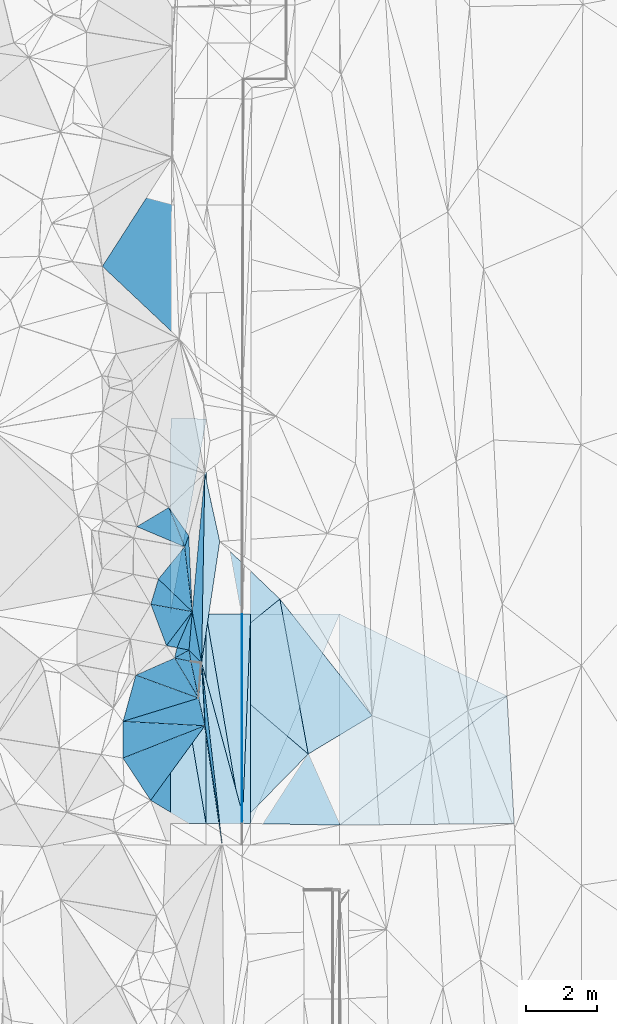
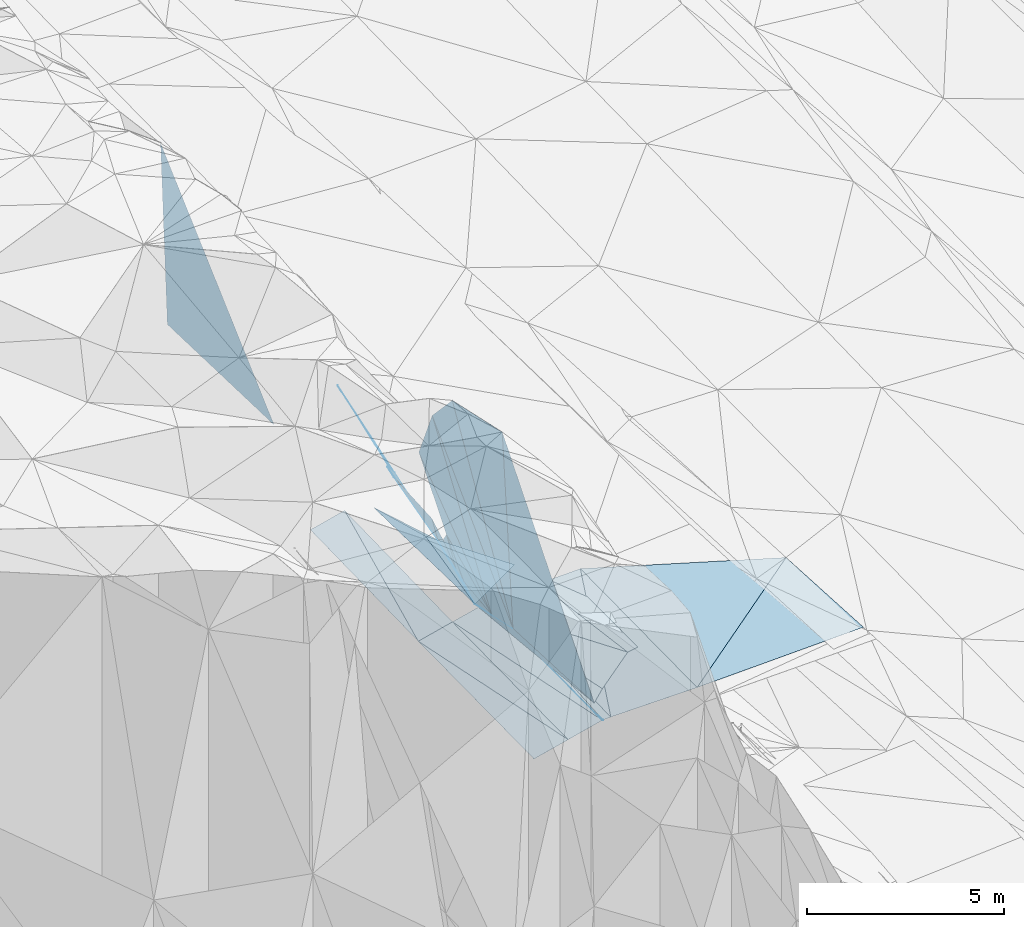
# One storey, part 88 of 275: 45 plates.
"""IFC2X3 building model written with IfcOpenShell, lengths in millimetres."""

from ifc_helpers import new_model, si_unit, frame, origin_with_axes, place, context, subcontext, project, spatial, polyline, outline, extrude, material, type_object, element, save


model = new_model("IFC2X3")

# Units and contexts
model_context = context("Model", 3, precision=1e-05, world=origin_with_axes())
body_context = subcontext(model_context, "Body", "Model", "MODEL_VIEW")
ifc_project = project(units=[si_unit("LENGTHUNIT", "METRE", prefix="MILLI"), si_unit("AREAUNIT", "SQUARE_METRE"), si_unit("VOLUMEUNIT", "CUBIC_METRE"), si_unit("MASSUNIT", "GRAM", prefix="KILO"), si_unit("TIMEUNIT", "SECOND"), si_unit("PLANEANGLEUNIT", "RADIAN"), si_unit("SOLIDANGLEUNIT", "STERADIAN"), si_unit("THERMODYNAMICTEMPERATUREUNIT", "DEGREE_CELSIUS"), si_unit("LUMINOUSINTENSITYUNIT", "LUMEN")], contexts=[model_context])

# Site, building, storey
site_placement = place(None, origin_with_axes())
site = spatial("IfcSite", under=ifc_project, at=site_placement, CompositionType="ELEMENT")
building_placement = place(site_placement, origin_with_axes())
building = spatial("IfcBuilding", under=site, at=building_placement, Name="Undefined", CompositionType="ELEMENT")
storey_placement = place(building_placement, origin_with_axes())
storey = spatial("IfcBuildingStorey", under=building, at=storey_placement, Name="Undefined", CompositionType="ELEMENT", Elevation=0.0)

# Plates
ifc_material = material()
plate_type_1 = type_object("IfcPlateType", PredefinedType="NOTDEFINED")
plate_1_placement = place(storey_placement, frame((-96893.2060687271, 88513.7220554955, 42669.7156715299), z_axis=(0.0499446714186171, 0.0138763250897075, -0.998655584973564), x_axis=(0.998751959117345, -0.000926466934522729, 0.0499366180100698)))
element("IfcPlate", 1, at=plate_1_placement, inside=storey, type_object=plate_type_1, material=ifc_material, Name="00_PR", context=body_context, shape_type="SweptSolid", body=[
    extrude(outline(polyline([(0.0, 0.0), (20.0253849029541, -2.91038304567337e-11), (18.7645778656006, 5873.8154296875), (0.0, 0.0)])), frame((-8.85201319254618e-08, 2.18876761149539e-07, -0.5000001331573), z_axis=(0.0, 0.0, 1.0), x_axis=(1.0, 0.0, 0.0)), (0.0, 0.0, 1.0), 1.0),
])
plate_2_placement = place(storey_placement, frame((-96875.8293149701, 82640.4574952673, 42588.975671324), z_axis=(0.0499313186515938, 0.0138762943318531, -0.998656253108811), x_axis=(-0.998752336887463, -0.000102790084437559, -0.0499375509614761)))
element("IfcPlate", 2, at=plate_2_placement, inside=storey, type_object=plate_type_1, material=ifc_material, Name="00_PR", context=body_context, shape_type="SweptSolid", body=[
    extrude(outline(polyline([(0.0, 0.0), (20.0249881744385, 1.60071067512035e-10), (12.719409942627, 5873.83154296875), (0.0, 0.0)])), frame((-8.85201319254618e-08, 2.18876761149539e-07, -0.5000001331573), z_axis=(0.0, 0.0, 1.0), x_axis=(1.0, 0.0, 0.0)), (0.0, 0.0, 1.0), 1.0),
])
plate_type_2 = type_object("IfcPlateType", PredefinedType="NOTDEFINED")
plate_3_placement = place(storey_placement, frame((-96643.206190822, 88513.4879067641, 42682.2156707472), z_axis=(0.0499458955257397, 0.0138763235076021, -0.998655523774862), x_axis=(-0.0395726899371841, -0.999090793774861, -0.0158615259496958)))
element("IfcPlate", 3, at=plate_3_placement, inside=storey, type_object=plate_type_2, material=ifc_material, Name="00_PR", context=body_context, shape_type="SweptSolid", body=[
    extrude(outline(polyline([(0.0, 0.0), (5878.375, 8.45466274768114e-09), (9.06870937347412, 230.108276367188), (0.0, 0.0)])), frame((-8.85201319254618e-08, 2.18876761149539e-07, -0.5000001331573), z_axis=(0.0, 0.0, 1.0), x_axis=(1.0, 0.0, 0.0)), (0.0, 0.0, 1.0), 1.0),
])
plate_4_placement = place(storey_placement, frame((-96875.8293149701, 82640.4574952673, 42588.975671324), z_axis=(0.049932272950596, 0.0138768737776843, -0.998656197343283), x_axis=(0.0395726899278076, 0.999090793775177, 0.0158615259532447)))
element("IfcPlate", 4, at=plate_4_placement, inside=storey, type_object=plate_type_2, material=ifc_material, Name="00_PR", context=body_context, shape_type="SweptSolid", body=[
    extrude(outline(polyline([(0.0, 0.0), (5878.375, 8.45466274768114e-09), (9.07760524749756, 230.108184814453), (0.0, 0.0)])), frame((-8.85201319254618e-08, 2.18876761149539e-07, -0.5000001331573), z_axis=(0.0, 0.0, 1.0), x_axis=(1.0, 0.0, 0.0)), (0.0, 0.0, 1.0), 1.0),
])
plate_type_3 = type_object("IfcPlateType", PredefinedType="NOTDEFINED")
plate_5_placement = place(storey_placement, frame((-98777.8240217178, 87283.3001653632, 46179.8436901109), z_axis=(-0.934762478303798, -0.168849738440227, -0.312584188634053), x_axis=(0.144226771959562, 0.623726465579778, -0.768221279570856)))
element("IfcPlate", 5, at=plate_5_placement, inside=storey, type_object=plate_type_3, material=ifc_material, Name="00", context=body_context, shape_type="SweptSolid", body=[
    extrude(outline(polyline([(0.0, 0.0), (468.614990234375, -1.94995664060116e-09), (1218.9111328125, 704.525207519531), (0.0, 0.0)])), frame((-8.85201319254618e-08, 2.18876761149539e-07, -0.5000001331573), z_axis=(0.0, 0.0, 1.0), x_axis=(1.0, 0.0, 0.0)), (0.0, 0.0, 1.0), 1.0),
])
plate_type_4 = type_object("IfcPlateType", PredefinedType="NOTDEFINED")
plate_6_placement = place(storey_placement, frame((-96895.7330487031, 82640.4551932555, 42587.9899716157), z_axis=(0.242514042864615, 0.0133900825096925, -0.970055485373823), x_axis=(-0.970142022389103, -0.000132066070191462, -0.242537500097065)))
element("IfcPlate", 6, at=plate_6_placement, inside=storey, type_object=plate_type_4, material=ifc_material, Name="00_PR", context=body_context, shape_type="SweptSolid", body=[
    extrude(outline(polyline([(0.0, 0.0), (1030.77673339844, -2.18278728425503e-09), (1007.62969970703, 5874.8642578125), (0.0, 0.0)])), frame((-8.85201319254618e-08, 2.18876761149539e-07, -0.5000001331573), z_axis=(0.0, 0.0, 1.0), x_axis=(1.0, 0.0, 0.0)), (0.0, 0.0, 1.0), 1.0),
])
plate_7_placement = place(storey_placement, frame((-98893.1086731115, 88515.5972124525, 42169.7299724131), z_axis=(0.242525718614179, 0.0133900365415608, -0.970052566994228), x_axis=(0.97014209331027, -0.000909506926827291, 0.242535547053866)))
element("IfcPlate", 7, at=plate_7_placement, inside=storey, type_object=plate_type_4, material=ifc_material, Name="00_PR", context=body_context, shape_type="SweptSolid", body=[
    extrude(outline(polyline([(0.0, 0.0), (1030.77673339844, -2.18278728425503e-09), (1013.74847412109, 5874.88525390625), (0.0, 0.0)])), frame((-8.85201319254618e-08, 2.18876761149539e-07, -0.5000001331573), z_axis=(0.0, 0.0, 1.0), x_axis=(1.0, 0.0, 0.0)), (0.0, 0.0, 1.0), 1.0),
])
plate_8_placement = place(storey_placement, frame((-97895.7328316384, 82640.3190606472, 42337.9879714203), z_axis=(0.242513080573576, 0.0133878003581773, -0.970055757445047), x_axis=(-0.970142285513392, -0.000125957083561735, -0.24253645085567)))
element("IfcPlate", 8, at=plate_8_placement, inside=storey, type_object=plate_type_4, material=ifc_material, Name="00_PR", context=body_context, shape_type="SweptSolid", body=[
    extrude(outline(polyline([(0.0, 0.0), (1030.77697753906, -6.40284270048141e-10), (1007.66516113281, 5875.931640625), (0.0, 0.0)])), frame((-8.85201319254618e-08, 2.18876761149539e-07, -0.5000001331573), z_axis=(0.0, 0.0, 1.0), x_axis=(1.0, 0.0, 0.0)), (0.0, 0.0, 1.0), 1.0),
])
plate_9_placement = place(storey_placement, frame((-96895.7330487031, 82640.4551932555, 42587.9899716157), z_axis=(0.242525927545309, 0.0133921862289311, -0.970052485083306), x_axis=(-0.167326671140559, 0.985497305366927, -0.028228465058257)))
element("IfcPlate", 9, at=plate_9_placement, inside=storey, type_object=plate_type_4, material=ifc_material, Name="00_PR", context=body_context, shape_type="SweptSolid", body=[
    extrude(outline(polyline([(0.0, 0.0), (5960.64990234375, -9.22591425478458e-09), (5785.34228515625, 1015.75885009766), (0.0, 0.0)])), frame((-8.85201319254618e-08, 2.18876761149539e-07, -0.5000001331573), z_axis=(0.0, 0.0, 1.0), x_axis=(1.0, 0.0, 0.0)), (0.0, 0.0, 1.0), 1.0),
])
plate_type_5 = type_object("IfcPlateType", PredefinedType="NOTDEFINED")
plate_10_placement = place(storey_placement, frame((-97885.4748993714, 93996.4223844133, 42542.8030438031), z_axis=(0.242517661901467, 0.0214344360912746, -0.969910175539619), x_axis=(-0.180412993918953, -0.981320168044632, -0.0667973009488785)))
element("IfcPlate", 10, at=plate_10_placement, inside=storey, type_object=plate_type_5, material=ifc_material, Name="00_PR", context=body_context, shape_type="SweptSolid", body=[
    extrude(outline(polyline([(0.0, 0.0), (5585.15087890625, -2.30938894674182e-08), (195.298400878906, 1012.10559082031), (0.0, 0.0)])), frame((-8.85201319254618e-08, 2.18876761149539e-07, -0.5000001331573), z_axis=(0.0, 0.0, 1.0), x_axis=(1.0, 0.0, 0.0)), (0.0, 0.0, 1.0), 1.0),
])
plate_11_placement = place(storey_placement, frame((-98893.1086889943, 88515.6012354554, 42169.7300417344), z_axis=(0.242499038802853, 0.0214382132062527, -0.969914748415661), x_axis=(0.180412993916078, 0.981320168044951, 0.0667973009519616)))
element("IfcPlate", 11, at=plate_11_placement, inside=storey, type_object=plate_type_5, material=ifc_material, Name="00_PR", context=body_context, shape_type="SweptSolid", body=[
    extrude(outline(polyline([(0.0, 0.0), (5585.15087890625, -2.30938894674182e-08), (196.192321777344, 1011.93341064453), (0.0, 0.0)])), frame((-8.85201319254618e-08, 2.18876761149539e-07, -0.5000001331573), z_axis=(0.0, 0.0, 1.0), x_axis=(1.0, 0.0, 0.0)), (0.0, 0.0, 1.0), 1.0),
])
plate_type_6 = type_object("IfcPlateType", PredefinedType="NOTDEFINED")
plate_12_placement = place(storey_placement, frame((-98321.0967344729, 87190.1452454578, 44619.8206200758), z_axis=(-0.927169515903314, 0.108044872178601, -0.358724120147396), x_axis=(-0.132361426280136, 0.801291839814366, 0.583448232733631)))
element("IfcPlate", 12, at=plate_12_placement, inside=storey, type_object=plate_type_6, material=ifc_material, Name="00", context=body_context, shape_type="SweptSolid", body=[
    extrude(outline(polyline([(0.0, 0.0), (394.208068847656, 5.0931703299284e-10), (-525.559997558594, 656.521667480469), (0.0, 0.0)])), frame((-8.85201319254618e-08, 2.18876761149539e-07, -0.5000001331573), z_axis=(0.0, 0.0, 1.0), x_axis=(1.0, 0.0, 0.0)), (0.0, 0.0, 1.0), 1.0),
])
plate_type_7 = type_object("IfcPlateType", PredefinedType="NOTDEFINED")
plate_13_placement = place(storey_placement, frame((-89450.8198160826, 86219.6799809092, 42848.685236372), z_axis=(0.0255600534766199, 0.0172621321198634, -0.999524238055761), x_axis=(0.0555775201133517, -0.998329033409946, -0.0158202499605024)))
element("IfcPlate", 13, at=plate_13_placement, inside=storey, type_object=plate_type_7, material=ifc_material, Name="00_PR", context=body_context, shape_type="SweptSolid", body=[
    extrude(outline(polyline([(0.0, 0.0), (3585.7841796875, -4.32191882282496e-09), (3360.41650390625, 4891.17724609375), (0.0, 0.0)])), frame((-8.85201319254618e-08, 2.18876761149539e-07, -0.5000001331573), z_axis=(0.0, 0.0, 1.0), x_axis=(1.0, 0.0, 0.0)), (0.0, 0.0, 1.0), 1.0),
])
plate_type_8 = type_object("IfcPlateType", PredefinedType="NOTDEFINED")
plate_14_placement = place(storey_placement, frame((-98281.8003223209, 88585.1772316541, 45059.8151830201), z_axis=(-0.917061441723247, 0.149655219156459, -0.369596573961003), x_axis=(0.136984403376972, -0.752244078327522, -0.64448748618777)))
element("IfcPlate", 14, at=plate_14_placement, inside=storey, type_object=plate_type_8, material=ifc_material, Name="00", context=body_context, shape_type="SweptSolid", body=[
    extrude(outline(polyline([(0.0, 0.0), (1900.73510742188, 9.85164660960436e-09), (934.585754394531, 586.130920410156), (0.0, 0.0)])), frame((-8.85201319254618e-08, 2.18876761149539e-07, -0.5000001331573), z_axis=(0.0, 0.0, 1.0), x_axis=(1.0, 0.0, 0.0)), (0.0, 0.0, 1.0), 1.0),
])
plate_type_9 = type_object("IfcPlateType", PredefinedType="NOTDEFINED")
plate_15_placement = place(storey_placement, frame((-94147.9689940766, 88514.5259286479, 42755.1682607573), z_axis=(0.0292156920013798, 0.0138975437163812, -0.99947651379086), x_axis=(-0.391198783795324, -0.91998725272795, -0.0242273889459753)))
element("IfcPlate", 15, at=plate_15_placement, inside=storey, type_object=plate_type_9, material=ifc_material, Name="00_PR", context=body_context, shape_type="SweptSolid", body=[
    extrude(outline(polyline([(0.0, 0.0), (6385.169921875, -1.02008925750852e-08), (978.860229492188, 2296.39208984375), (0.0, 0.0)])), frame((-8.85201319254618e-08, 2.18876761149539e-07, -0.5000001331573), z_axis=(0.0, 0.0, 1.0), x_axis=(1.0, 0.0, 0.0)), (0.0, 0.0, 1.0), 1.0),
])
plate_type_10 = type_object("IfcPlateType", PredefinedType="NOTDEFINED")
plate_16_placement = place(storey_placement, frame((-96645.841133087, 82640.2514278124, 42600.4722312239), z_axis=(0.0264812327337204, 0.0150618580365435, -0.999535834647958), x_axis=(0.391198783793806, 0.919987252728506, 0.0242273889493393)))
element("IfcPlate", 16, at=plate_16_placement, inside=storey, type_object=plate_type_10, material=ifc_material, Name="00_PR", context=body_context, shape_type="SweptSolid", body=[
    extrude(outline(polyline([(0.0, 0.0), (6385.169921875, -1.02008925750852e-08), (937.997375488281, 2318.47705078125), (0.0, 0.0)])), frame((-8.85201319254618e-08, 2.18876761149539e-07, -0.5000001331573), z_axis=(0.0, 0.0, 1.0), x_axis=(1.0, 0.0, 0.0)), (0.0, 0.0, 1.0), 1.0),
])
plate_type_11 = type_object("IfcPlateType", PredefinedType="NOTDEFINED")
plate_17_placement = place(storey_placement, frame((-94146.0719650738, 82595.1451738821, 42666.0202418753), z_axis=(0.0272582592440568, 0.0150617925048628, -0.999514947216661), x_axis=(-0.00032060709218387, 0.999886560717147, 0.0150586489542769)))
element("IfcPlate", 17, at=plate_17_placement, inside=storey, type_object=plate_type_11, material=ifc_material, Name="00_PR", context=body_context, shape_type="SweptSolid", body=[
    extrude(outline(polyline([(0.0, 0.0), (5920.052734375, 5.80621417611837e-09), (3625.36791992188, 4698.1611328125), (0.0, 0.0)])), frame((-8.85201319254618e-08, 2.18876761149539e-07, -0.5000001331573), z_axis=(0.0, 0.0, 1.0), x_axis=(1.0, 0.0, 0.0)), (0.0, 0.0, 1.0), 1.0),
])
plate_type_12 = type_object("IfcPlateType", PredefinedType="NOTDEFINED")
plate_18_placement = place(storey_placement, frame((-99232.3742871963, 89498.8382816605, 47089.7596187691), z_axis=(-0.859458469478843, 0.173882204639042, -0.480724576187811), x_axis=(0.481452232243517, 0.591457912349138, -0.646823999235753)))
element("IfcPlate", 18, at=plate_18_placement, inside=storey, type_object=plate_type_12, material=ifc_material, Name="00", context=body_context, shape_type="SweptSolid", body=[
    extrude(outline(polyline([(0.0, 0.0), (1530.55541992188, -8.14907252788544e-09), (1230.33764648438, 2084.60278320313), (0.0, 0.0)])), frame((-8.85201319254618e-08, 2.18876761149539e-07, -0.5000001331573), z_axis=(0.0, 0.0, 1.0), x_axis=(1.0, 0.0, 0.0)), (0.0, 0.0, 1.0), 1.0),
])
plate_type_13 = type_object("IfcPlateType", PredefinedType="NOTDEFINED")
plate_19_placement = place(storey_placement, frame((-98105.7364801051, 86159.0151946346, 44149.6651417027), z_axis=(-0.727312380144922, -0.150134864681754, -0.669683674651637), x_axis=(0.0805198648191997, 0.950373459793389, -0.30051096201277)))
element("IfcPlate", 19, at=plate_19_placement, inside=storey, type_object=plate_type_13, material=ifc_material, Name="00", context=body_context, shape_type="SweptSolid", body=[
    extrude(outline(polyline([(0.0, 0.0), (1048.21472167969, 3.11410985887051e-09), (-715.273315429688, 345.953857421875), (0.0, 0.0)])), frame((-8.85201319254618e-08, 2.18876761149539e-07, -0.5000001331573), z_axis=(0.0, 0.0, 1.0), x_axis=(1.0, 0.0, 0.0)), (0.0, 0.0, 1.0), 1.0),
])
plate_type_14 = type_object("IfcPlateType", PredefinedType="NOTDEFINED")
plate_20_placement = place(storey_placement, frame((-98105.8628060344, 86159.1004533628, 44149.9009383734), z_axis=(-0.979972063051786, 0.0203914954245451, -0.198088219115566), x_axis=(0.068057929838988, 0.969140463819479, -0.236928005043297)))
element("IfcPlate", 20, at=plate_20_placement, inside=storey, type_object=plate_type_14, material=ifc_material, Name="00", context=body_context, shape_type="SweptSolid", body=[
    extrude(outline(polyline([(0.0, 0.0), (1012.96594238281, -7.56699591875076e-10), (1045.82983398438, 70.6679916381836), (0.0, 0.0)])), frame((-8.85201319254618e-08, 2.18876761149539e-07, -0.5000001331573), z_axis=(0.0, 0.0, 1.0), x_axis=(1.0, 0.0, 0.0)), (0.0, 0.0, 1.0), 1.0),
])
plate_type_15 = type_object("IfcPlateType", PredefinedType="NOTDEFINED")
plate_21_placement = place(storey_placement, frame((-97447.4137552242, 82098.4392566977, 43641.5191021285), z_axis=(-0.273834591540273, 0.00564036593820448, -0.961760262616446), x_axis=(-0.112644817589187, 0.992912419165635, 0.0378955529969537)))
element("IfcPlate", 21, at=plate_21_placement, inside=storey, type_object=plate_type_15, material=ifc_material, Name="00", context=body_context, shape_type="SweptSolid", body=[
    extrude(outline(polyline([(0.0, 0.0), (5092.94580078125, -2.7648638933897e-09), (574.982360839844, 714.408325195313), (0.0, 0.0)])), frame((-8.85201319254618e-08, 2.18876761149539e-07, -0.5000001331573), z_axis=(0.0, 0.0, 1.0), x_axis=(1.0, 0.0, 0.0)), (0.0, 0.0, 1.0), 1.0),
])
plate_type_16 = type_object("IfcPlateType", PredefinedType="NOTDEFINED")
plate_22_placement = place(storey_placement, frame((-98495.4960429198, 90404.0845346859, 46099.775959327), z_axis=(-0.881658000523161, 0.148113976680984, -0.448041761474584), x_axis=(-0.42197435097039, 0.177540621864269, 0.889053977388981)))
element("IfcPlate", 22, at=plate_22_placement, inside=storey, type_object=plate_type_16, material=ifc_material, Name="00", context=body_context, shape_type="SweptSolid", body=[
    extrude(outline(polyline([(0.0, 0.0), (3183.15869140625, -1.61162461154163e-08), (1486.1337890625, 864.121643066406), (0.0, 0.0)])), frame((-8.85201319254618e-08, 2.18876761149539e-07, -0.5000001331573), z_axis=(0.0, 0.0, 1.0), x_axis=(1.0, 0.0, 0.0)), (0.0, 0.0, 1.0), 1.0),
])
plate_type_17 = type_object("IfcPlateType", PredefinedType="NOTDEFINED")
plate_23_placement = place(storey_placement, frame((-98321.0974953364, 87190.078606724, 44619.8149882167), z_axis=(-0.928693757813097, -0.0252342668824057, -0.369988021392444), x_axis=(0.370847310266728, -0.0643235600200336, -0.926463572999113)))
element("IfcPlate", 23, at=plate_23_placement, inside=storey, type_object=plate_type_17, material=ifc_material, Name="00", context=body_context, shape_type="SweptSolid", body=[
    extrude(outline(polyline([(0.0, 0.0), (766.35498046875, -1.57160684466362e-09), (581.584228515625, 995.971740722656), (0.0, 0.0)])), frame((-8.85201319254618e-08, 2.18876761149539e-07, -0.5000001331573), z_axis=(0.0, 0.0, 1.0), x_axis=(1.0, 0.0, 0.0)), (0.0, 0.0, 1.0), 1.0),
])
plate_type_18 = type_object("IfcPlateType", PredefinedType="NOTDEFINED")
plate_24_placement = place(storey_placement, frame((-99444.9668822215, 88792.4641744932, 47279.769787258), z_axis=(-0.886603798355503, -0.0444636372513324, -0.460387542950477), x_axis=(0.462527894079909, -0.0824642259381889, -0.882761348631905)))
element("IfcPlate", 24, at=plate_24_placement, inside=storey, type_object=plate_type_18, material=ifc_material, Name="00", context=body_context, shape_type="SweptSolid", body=[
    extrude(outline(polyline([(0.0, 0.0), (2514.8359375, -3.46335582435131e-09), (942.566467285156, 1089.48083496094), (0.0, 0.0)])), frame((-8.85201319254618e-08, 2.18876761149539e-07, -0.5000001331573), z_axis=(0.0, 0.0, 1.0), x_axis=(1.0, 0.0, 0.0)), (0.0, 0.0, 1.0), 1.0),
])
plate_type_19 = type_object("IfcPlateType", PredefinedType="NOTDEFINED")
plate_25_placement = place(storey_placement, frame((-98281.8042617802, 88585.1528356202, 45059.8167464526), z_axis=(-0.924947908904601, 0.100858872069226, -0.366468080107845), x_axis=(-0.101473052272716, 0.863633872157514, 0.493801331027649)))
element("IfcPlate", 25, at=plate_25_placement, inside=storey, type_object=plate_type_19, material=ifc_material, Name="00", context=body_context, shape_type="SweptSolid", body=[
    extrude(outline(polyline([(0.0, 0.0), (2106.11010742188, 3.44152795150876e-09), (2265.74096679688, 353.578857421875), (0.0, 0.0)])), frame((-8.85201319254618e-08, 2.18876761149539e-07, -0.5000001331573), z_axis=(0.0, 0.0, 1.0), x_axis=(1.0, 0.0, 0.0)), (0.0, 0.0, 1.0), 1.0),
])
plate_type_20 = type_object("IfcPlateType", PredefinedType="NOTDEFINED")
plate_26_placement = place(storey_placement, frame((-100227.146582165, 84477.6299716355, 52539.8592435323), z_axis=(-0.913287548215604, -0.294408441257502, -0.281477395168172), x_axis=(0.00270249300518234, 0.686660010995225, -0.726973676161382)))
element("IfcPlate", 26, at=plate_26_placement, inside=storey, type_object=plate_type_20, material=ifc_material, Name="00", context=body_context, shape_type="SweptSolid", body=[
    extrude(outline(polyline([(0.0, 0.0), (1499.36657714844, 6.09725248068571e-09), (6743.0478515625, 5600.92041015625), (0.0, 0.0)])), frame((-8.85201319254618e-08, 2.18876761149539e-07, -0.5000001331573), z_axis=(0.0, 0.0, 1.0), x_axis=(1.0, 0.0, 0.0)), (0.0, 0.0, 1.0), 1.0),
])
plate_type_21 = type_object("IfcPlateType", PredefinedType="NOTDEFINED")
plate_27_placement = place(storey_placement, frame((-98105.8466902804, 86159.0949634945, 44149.8405155578), z_axis=(-0.947730314883976, 0.00940692080922407, -0.318933786373924), x_axis=(-0.315789356125315, 0.115369265977426, 0.941789262534772)))
element("IfcPlate", 27, at=plate_27_placement, inside=storey, type_object=plate_type_21, material=ifc_material, Name="00", context=body_context, shape_type="SweptSolid", body=[
    extrude(outline(polyline([(0.0, 0.0), (5574.49560546875, 3.47790773957968e-09), (2253.74658203125, 870.130126953125), (0.0, 0.0)])), frame((-8.85201319254618e-08, 2.18876761149539e-07, -0.5000001331573), z_axis=(0.0, 0.0, 1.0), x_axis=(1.0, 0.0, 0.0)), (0.0, 0.0, 1.0), 1.0),
])
plate_type_22 = type_object("IfcPlateType", PredefinedType="NOTDEFINED")
plate_28_placement = place(storey_placement, frame((-98020.9347180375, 87155.261962115, 43834.5018396694), z_axis=(0.0720637196527174, -0.0474300322571776, -0.996271655900085), x_axis=(0.0171934773813364, 0.998779335732133, -0.046305753962291)))
element("IfcPlate", 28, at=plate_28_placement, inside=storey, type_object=plate_type_22, material=ifc_material, Name="00", context=body_context, shape_type="SweptSolid", body=[
    extrude(outline(polyline([(0.0, 0.0), (5312.5146484375, -1.42608769237995e-08), (3409.48852539063, 451.688079833984), (0.0, 0.0)])), frame((-8.85201319254618e-08, 2.18876761149539e-07, -0.5000001331573), z_axis=(0.0, 0.0, 1.0), x_axis=(1.0, 0.0, 0.0)), (0.0, 0.0, 1.0), 1.0),
])
plate_type_23 = type_object("IfcPlateType", PredefinedType="NOTDEFINED")
plate_29_placement = place(storey_placement, frame((-97930.1183659386, 92461.319036732, 43588.892228157), z_axis=(-0.976478589062838, 0.00681819189209248, -0.215506559902876), x_axis=(-0.0171934777789524, -0.998779335722332, 0.0463057540260519)))
element("IfcPlate", 29, at=plate_29_placement, inside=storey, type_object=plate_type_23, material=ifc_material, Name="00", context=body_context, shape_type="SweptSolid", body=[
    extrude(outline(polyline([(0.0, 0.0), (5312.5146484375, -1.42608769237995e-08), (3945.64453125, 1320.78002929688), (0.0, 0.0)])), frame((-8.85201319254618e-08, 2.18876761149539e-07, -0.5000001331573), z_axis=(0.0, 0.0, 1.0), x_axis=(1.0, 0.0, 0.0)), (0.0, 0.0, 1.0), 1.0),
])
plate_type_24 = type_object("IfcPlateType", PredefinedType="NOTDEFINED")
plate_30_placement = place(storey_placement, frame((-98940.0970807988, 91508.605522994, 47339.8014893717), z_axis=(-0.914543491627388, 0.0775572210089061, -0.396982467360161), x_axis=(0.321451785098883, -0.456364158757029, -0.829699044508749)))
element("IfcPlate", 30, at=plate_30_placement, inside=storey, type_object=plate_type_24, material=ifc_material, Name="00", context=body_context, shape_type="SweptSolid", body=[
    extrude(outline(polyline([(0.0, 0.0), (1735.56909179688, -2.47382558882236e-09), (1675.81921386719, 383.314422607422), (0.0, 0.0)])), frame((-8.85201319254618e-08, 2.18876761149539e-07, -0.5000001331573), z_axis=(0.0, 0.0, 1.0), x_axis=(1.0, 0.0, 0.0)), (0.0, 0.0, 1.0), 1.0),
])
plate_type_25 = type_object("IfcPlateType", PredefinedType="NOTDEFINED")
plate_31_placement = place(storey_placement, frame((-99444.9597087256, 88792.5544898196, 47279.7651116524), z_axis=(-0.872241958621989, 0.136167620638799, -0.469736463039484), x_axis=(0.279105872746191, 0.927291357677803, -0.24946071789892)))
element("IfcPlate", 31, at=plate_31_placement, inside=storey, type_object=plate_type_25, material=ifc_material, Name="00", context=body_context, shape_type="SweptSolid", body=[
    extrude(outline(polyline([(0.0, 0.0), (761.642944335938, -1.38243194669485e-09), (686.148254394531, 2419.42163085938), (0.0, 0.0)])), frame((-8.85201319254618e-08, 2.18876761149539e-07, -0.5000001331573), z_axis=(0.0, 0.0, 1.0), x_axis=(1.0, 0.0, 0.0)), (0.0, 0.0, 1.0), 1.0),
])
plate_type_26 = type_object("IfcPlateType", PredefinedType="NOTDEFINED")
plate_32_placement = place(storey_placement, frame((-98710.235583582, 87575.7441279237, 45819.8330111783), z_axis=(-0.931538016826158, 0.143943840898051, -0.333941752219014), x_axis=(0.321111365858935, 0.756578705751124, -0.569628082805055)))
element("IfcPlate", 32, at=plate_32_placement, inside=storey, type_object=plate_type_26, material=ifc_material, Name="00", context=body_context, shape_type="SweptSolid", body=[
    extrude(outline(polyline([(0.0, 0.0), (1334.20385742188, 2.8085196390748e-09), (608.003051757813, 830.441040039063), (0.0, 0.0)])), frame((-8.85201319254618e-08, 2.18876761149539e-07, -0.5000001331573), z_axis=(0.0, 0.0, 1.0), x_axis=(1.0, 0.0, 0.0)), (0.0, 0.0, 1.0), 1.0),
])
plate_type_27 = type_object("IfcPlateType", PredefinedType="NOTDEFINED")
plate_33_placement = place(storey_placement, frame((-98105.8400133916, 86158.9864465001, 44149.8552123812), z_axis=(-0.934375651168971, -0.207626228954345, -0.289540138068559), x_axis=(0.224275753200454, -0.97420058168882, -0.0251716738325948)))
element("IfcPlate", 33, at=plate_33_placement, inside=storey, type_object=plate_type_27, material=ifc_material, Name="00", context=body_context, shape_type="SweptSolid", body=[
    extrude(outline(polyline([(0.0, 0.0), (794.543884277344, 2.52475729212165e-09), (-23.6613731384277, 7628.6982421875), (0.0, 0.0)])), frame((-8.85201319254618e-08, 2.18876761149539e-07, -0.5000001331573), z_axis=(0.0, 0.0, 1.0), x_axis=(1.0, 0.0, 0.0)), (0.0, 0.0, 1.0), 1.0),
])
plate_type_28 = type_object("IfcPlateType", PredefinedType="NOTDEFINED")
plate_34_placement = place(storey_placement, frame((-100227.117873265, 84477.5600359985, 52539.8595489349), z_axis=(-0.855874771530016, -0.434271521609591, -0.280867621803108), x_axis=(0.262328342050918, 0.103501042901534, -0.959411994439882)))
element("IfcPlate", 34, at=plate_34_placement, inside=storey, type_object=plate_type_28, material=ifc_material, Name="00", context=body_context, shape_type="SweptSolid", body=[
    extrude(outline(polyline([(0.0, 0.0), (8765.7861328125, 2.35158950090408e-08), (589.268310546875, 1395.19274902344), (0.0, 0.0)])), frame((-8.85201319254618e-08, 2.18876761149539e-07, -0.5000001331573), z_axis=(0.0, 0.0, 1.0), x_axis=(1.0, 0.0, 0.0)), (0.0, 0.0, 1.0), 1.0),
])
plate_type_29 = type_object("IfcPlateType", PredefinedType="NOTDEFINED")
plate_35_placement = place(storey_placement, frame((-99007.6192884844, 87630.1206614809, 46549.8090674459), z_axis=(-0.918545475624192, 0.10237498201807, -0.381829244908148), x_axis=(0.379443107842433, 0.499271919704768, -0.778941896488558)))
element("IfcPlate", 35, at=plate_35_placement, inside=storey, type_object=plate_type_29, material=ifc_material, Name="00", context=body_context, shape_type="SweptSolid", body=[
    extrude(outline(polyline([(0.0, 0.0), (1912.85131835938, -1.19325704872608e-09), (654.311218261719, 442.918579101563), (0.0, 0.0)])), frame((-8.85201319254618e-08, 2.18876761149539e-07, -0.5000001331573), z_axis=(0.0, 0.0, 1.0), x_axis=(1.0, 0.0, 0.0)), (0.0, 0.0, 1.0), 1.0),
])
plate_type_30 = type_object("IfcPlateType", PredefinedType="NOTDEFINED")
plate_36_placement = place(storey_placement, frame((-97927.6609426027, 85384.9903931642, 44129.8916791137), z_axis=(-0.970099408452947, -0.109488130049989, -0.21660906513209), x_axis=(0.142949719256334, -0.978996958891602, -0.145362760862369)))
element("IfcPlate", 36, at=plate_36_placement, inside=storey, type_object=plate_type_30, material=ifc_material, Name="00", context=body_context, shape_type="SweptSolid", body=[
    extrude(outline(polyline([(0.0, 0.0), (3357.11840820313, -1.10812834464014e-08), (687.542053222656, 8266.1533203125), (0.0, 0.0)])), frame((-8.85201319254618e-08, 2.18876761149539e-07, -0.5000001331573), z_axis=(0.0, 0.0, 1.0), x_axis=(1.0, 0.0, 0.0)), (0.0, 0.0, 1.0), 1.0),
])
plate_type_31 = type_object("IfcPlateType", PredefinedType="NOTDEFINED")
plate_37_placement = place(storey_placement, frame((-99866.2072029911, 86802.1156629987, 49399.8553018425), z_axis=(-0.936072085122405, -0.200099358930639, -0.289360152768382), x_axis=(0.315789356123131, -0.115369265979641, -0.941789262535232)))
element("IfcPlate", 37, at=plate_37_placement, inside=storey, type_object=plate_type_31, material=ifc_material, Name="00", context=body_context, shape_type="SweptSolid", body=[
    extrude(outline(polyline([(0.0, 0.0), (5574.49560546875, 3.47790773957968e-09), (-1893.98303222656, 1555.451171875), (0.0, 0.0)])), frame((-8.85201319254618e-08, 2.18876761149539e-07, -0.5000001331573), z_axis=(0.0, 0.0, 1.0), x_axis=(1.0, 0.0, 0.0)), (0.0, 0.0, 1.0), 1.0),
])
plate_type_32 = type_object("IfcPlateType", PredefinedType="NOTDEFINED")
plate_38_placement = place(storey_placement, frame((-98777.8357685142, 87283.3474904038, 46179.8619260357), z_axis=(-0.958256708694318, -0.074201358394212, -0.276112728165122), x_axis=(0.280515380350832, -0.0572999300673231, -0.95813769334105)))
element("IfcPlate", 38, at=plate_38_placement, inside=storey, type_object=plate_type_32, material=ifc_material, Name="00", context=body_context, shape_type="SweptSolid", body=[
    extrude(outline(polyline([(0.0, 0.0), (1628.15844726563, 4.72937244921923e-09), (2197.943359375, 1002.76879882813), (0.0, 0.0)])), frame((-8.85201319254618e-08, 2.18876761149539e-07, -0.5000001331573), z_axis=(0.0, 0.0, 1.0), x_axis=(1.0, 0.0, 0.0)), (0.0, 0.0, 1.0), 1.0),
])
plate_type_33 = type_object("IfcPlateType", PredefinedType="NOTDEFINED")
plate_39_placement = place(storey_placement, frame((-98021.4479690641, 87155.2368965738, 43834.8590863749), z_axis=(-0.954505426801986, -0.0975326943882112, -0.281792057607971), x_axis=(0.112644817241845, -0.992912419209341, -0.0378955528842886)))
element("IfcPlate", 39, at=plate_39_placement, inside=storey, type_object=plate_type_33, material=ifc_material, Name="00", context=body_context, shape_type="SweptSolid", body=[
    extrude(outline(polyline([(0.0, 0.0), (5092.94580078125, -2.7648638933897e-09), (1757.080078125, 377.151763916016), (0.0, 0.0)])), frame((-8.85201319254618e-08, 2.18876761149539e-07, -0.5000001331573), z_axis=(0.0, 0.0, 1.0), x_axis=(1.0, 0.0, 0.0)), (0.0, 0.0, 1.0), 1.0),
])
plate_type_34 = type_object("IfcPlateType", PredefinedType="NOTDEFINED")
plate_40_placement = place(storey_placement, frame((-98373.2900059755, 87505.9909598127, 44849.8583329046), z_axis=(-0.957826755331191, 0.04806079310126, -0.283298547363378), x_axis=(0.132361426285053, -0.801291839810213, -0.583448232738219)))
element("IfcPlate", 40, at=plate_40_placement, inside=storey, type_object=plate_type_34, material=ifc_material, Name="00", context=body_context, shape_type="SweptSolid", body=[
    extrude(outline(polyline([(0.0, 0.0), (394.208068847656, 5.0931703299284e-10), (-651.178955078125, 1248.22509765625), (0.0, 0.0)])), frame((-8.85201319254618e-08, 2.18876761149539e-07, -0.5000001331573), z_axis=(0.0, 0.0, 1.0), x_axis=(1.0, 0.0, 0.0)), (0.0, 0.0, 1.0), 1.0),
])
plate_type_35 = type_object("IfcPlateType", PredefinedType="NOTDEFINED")
plate_41_placement = place(storey_placement, frame((-98837.1645059164, 101336.41117382, 44182.8772991653), z_axis=(-0.968930691430725, -0.0311592829949407, -0.245361802827619), x_axis=(0.0366512432285758, -0.999168728249634, -0.01784765692772)))
element("IfcPlate", 41, at=plate_41_placement, inside=storey, type_object=plate_type_35, material=ifc_material, Name="00", context=body_context, shape_type="SweptSolid", body=[
    extrude(outline(polyline([(0.0, 0.0), (5098.70849609375, -2.76850187219679e-08), (2843.78686523438, 8468.0), (0.0, 0.0)])), frame((-8.85201319254618e-08, 2.18876761149539e-07, -0.5000001331573), z_axis=(0.0, 0.0, 1.0), x_axis=(1.0, 0.0, 0.0)), (0.0, 0.0, 1.0), 1.0),
])
plate_type_36 = type_object("IfcPlateType", PredefinedType="NOTDEFINED")
plate_42_placement = place(storey_placement, frame((-98021.1281174397, 87155.2824411233, 43834.5253973909), z_axis=(-0.314741545920307, -0.00647769197085815, -0.949155308038904), x_axis=(0.737005102025582, -0.631810850169442, -0.240080255740509)))
element("IfcPlate", 42, at=plate_42_placement, inside=storey, type_object=plate_type_36, material=ifc_material, Name="00", context=body_context, shape_type="SweptSolid", body=[
    extrude(outline(polyline([(0.0, 0.0), (4061.14184570313, 1.05628714663908e-08), (3746.30444335938, 2624.41943359375), (0.0, 0.0)])), frame((-8.85201319254618e-08, 2.18876761149539e-07, -0.5000001331573), z_axis=(0.0, 0.0, 1.0), x_axis=(1.0, 0.0, 0.0)), (0.0, 0.0, 1.0), 1.0),
])
plate_type_37 = type_object("IfcPlateType", PredefinedType="NOTDEFINED")
plate_43_placement = place(storey_placement, frame((-95028.0340496045, 84589.423928791, 42859.5218043338), z_axis=(-0.291293602207908, 0.023605264646192, -0.9563424223539), x_axis=(-0.737005102021768, 0.631810850172318, 0.240080255744648)))
element("IfcPlate", 43, at=plate_43_placement, inside=storey, type_object=plate_type_37, material=ifc_material, Name="00", context=body_context, shape_type="SweptSolid", body=[
    extrude(outline(polyline([(0.0, 0.0), (4061.14184570313, 1.05628714663908e-08), (3419.0751953125, 2825.47778320313), (0.0, 0.0)])), frame((-8.85201319254618e-08, 2.18876761149539e-07, -0.5000001331573), z_axis=(0.0, 0.0, 1.0), x_axis=(1.0, 0.0, 0.0)), (0.0, 0.0, 1.0), 1.0),
])
plate_type_38 = type_object("IfcPlateType", PredefinedType="NOTDEFINED")
plate_44_placement = place(storey_placement, frame((-98021.1099827661, 87155.28887103, 43834.5197640956), z_axis=(-0.278474029364717, 0.00638679158891659, -0.960422523612695), x_axis=(0.148015861345541, 0.988316931804166, -0.0363448359376752)))
element("IfcPlate", 44, at=plate_44_placement, inside=storey, type_object=plate_type_38, material=ifc_material, Name="00", context=body_context, shape_type="SweptSolid", body=[
    extrude(outline(polyline([(0.0, 0.0), (3439.27807617188, -1.88447302207351e-08), (2110.400390625, 1985.39270019531), (0.0, 0.0)])), frame((-8.85201319254618e-08, 2.18876761149539e-07, -0.5000001331573), z_axis=(0.0, 0.0, 1.0), x_axis=(1.0, 0.0, 0.0)), (0.0, 0.0, 1.0), 1.0),
])
plate_type_39 = type_object("IfcPlateType", PredefinedType="NOTDEFINED")
plate_45_placement = place(storey_placement, frame((-95824.6963430903, 88938.7022669172, 43209.5319506731), z_axis=(-0.351697454407232, 0.0109084788391666, -0.936050161931981), x_axis=(0.602553118552519, -0.762608908671954, -0.235281515926784)))
element("IfcPlate", 45, at=plate_45_placement, inside=storey, type_object=plate_type_39, material=ifc_material, Name="00", context=body_context, shape_type="SweptSolid", body=[
    extrude(outline(polyline([(0.0, 0.0), (4288.4794921875, -1.1066731531173e-08), (3879.1650390625, 2150.69287109375), (0.0, 0.0)])), frame((-8.85201319254618e-08, 2.18876761149539e-07, -0.5000001331573), z_axis=(0.0, 0.0, 1.0), x_axis=(1.0, 0.0, 0.0)), (0.0, 0.0, 1.0), 1.0),
])

save(model, "model.ifc")
